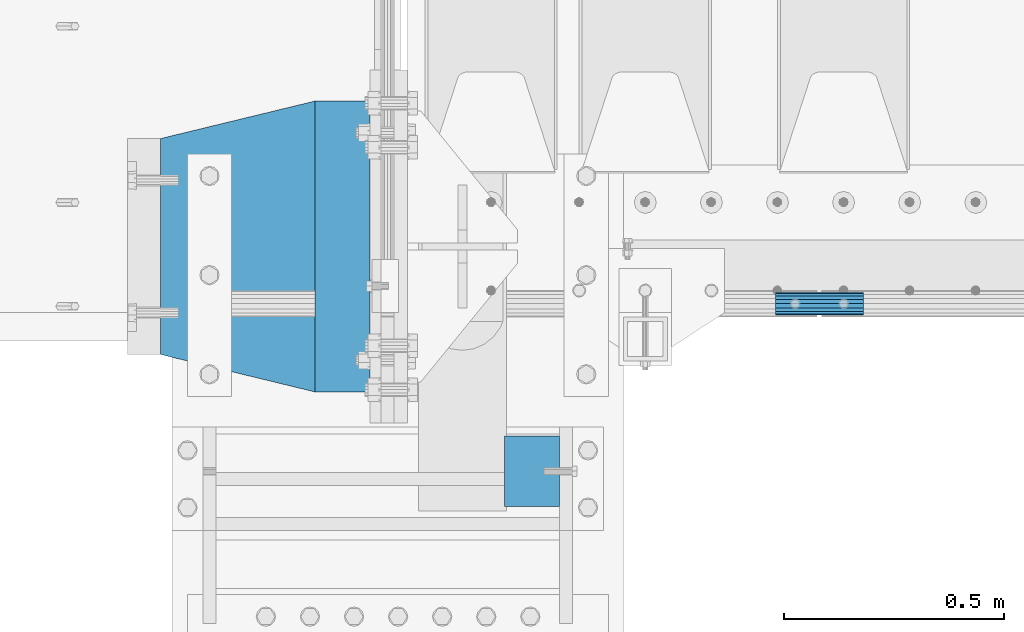
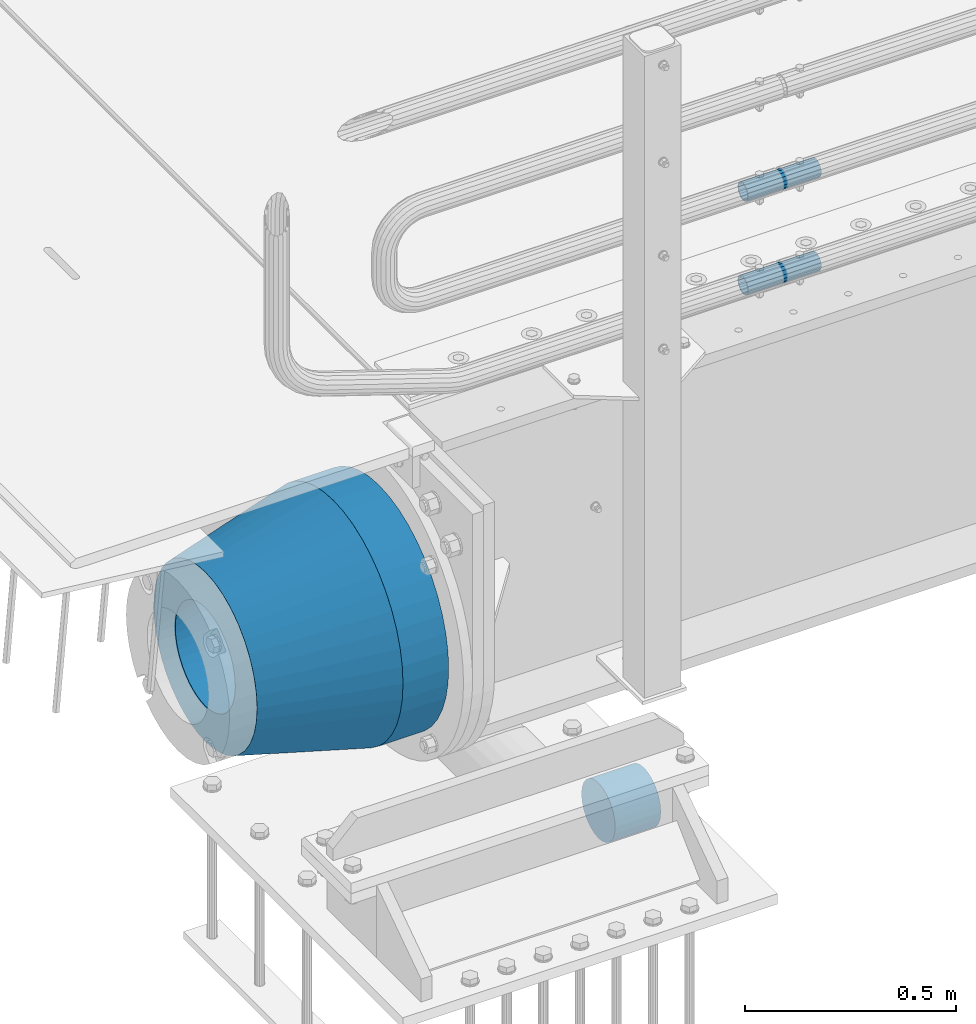
# One storey, part 137 of 247: 5 beams.
"""IFC2X3 building model written with IfcOpenShell, lengths in millimetres."""

from ifc_helpers import new_model, si_unit, frame, origin_with_axes, place, context, subcontext, project, spatial, faceted_brep, material, type_object, element, save


model = new_model("IFC2X3")

# Units and contexts
model_context = context("Model", 3, precision=1e-05, world=origin_with_axes())
body_context = subcontext(model_context, "Body", "Model", "MODEL_VIEW")
ifc_project = project(units=[si_unit("LENGTHUNIT", "METRE", prefix="MILLI"), si_unit("AREAUNIT", "SQUARE_METRE"), si_unit("VOLUMEUNIT", "CUBIC_METRE"), si_unit("MASSUNIT", "GRAM", prefix="KILO"), si_unit("TIMEUNIT", "SECOND"), si_unit("PLANEANGLEUNIT", "RADIAN"), si_unit("SOLIDANGLEUNIT", "STERADIAN"), si_unit("THERMODYNAMICTEMPERATUREUNIT", "DEGREE_CELSIUS"), si_unit("LUMINOUSINTENSITYUNIT", "LUMEN")], contexts=[model_context])

# Site, building, storey
site_placement = place(None, origin_with_axes())
site = spatial("IfcSite", under=ifc_project, at=site_placement, CompositionType="ELEMENT")
building_placement = place(site_placement, origin_with_axes())
building = spatial("IfcBuilding", under=site, at=building_placement, Name="Standard", CompositionType="ELEMENT")
storey_placement = place(building_placement, origin_with_axes())
storey = spatial("IfcBuildingStorey", under=building, at=storey_placement, Name="Undefined", CompositionType="ELEMENT", Elevation=0.0)

# Beams
ifc_material_1 = material()
beam_type_1 = type_object("IfcBeamType", PredefinedType="NOTDEFINED")
beam_1_placement = place(storey_placement, frame((230.000001139999, -510.000002261976, -923.000000000004), z_axis=(0.0, 0.0, -1.0), x_axis=(1.0, 0.0, 0.0)))
element("IfcBeam", 1, at=beam_1_placement, inside=storey, type_object=beam_type_1, material=ifc_material_1, context=body_context, shape_type="Brep", body=[
    faceted_brep([(2.8421709430404e-14, -80.0, 0.0), (2.8421709430404e-14, -77.2740661031254, -20.7055236082017), (125.0, -77.2740661031254, -20.7055236082017), (125.0, -80.0, 0.0), (2.8421709430404e-14, -69.2820323027551, -40.0), (125.0, -69.2820323027551, -40.0), (0.0, -56.5685424949238, -56.5685424949238), (125.0, -56.5685424949238, -56.5685424949238), (2.8421709430404e-14, -39.9999999999999, -69.2820323027552), (125.0, -39.9999999999999, -69.2820323027552), (2.8421709430404e-14, -20.7055236082016, -77.2740661031255), (125.0, -20.7055236082016, -77.2740661031255), (0.0, 0.0, -80.0), (125.0, 0.0, -80.0), (0.0, 20.7055236082018, -77.2740661031255), (125.0, 20.7055236082018, -77.2740661031255), (0.0, 40.0000000000001, -69.2820323027551), (125.0, 40.0000000000001, -69.2820323027551), (2.8421709430404e-14, 56.5685424949239, -56.5685424949238), (125.0, 56.5685424949239, -56.5685424949238), (0.0, 69.2820323027552, -40.0), (125.0, 69.2820323027551, -40.0), (0.0, 77.2740661031256, -20.7055236082016), (125.0, 77.2740661031256, -20.7055236082016), (0.0, 80.0000000000001, 0.0), (125.0, 80.0000000000001, 0.0), (0.0, 77.2740661031256, 20.7055236082017), (125.0, 77.2740661031254, 20.7055236082017), (0.0, 69.2820323027551, 40.0), (125.0, 69.2820323027551, 40.0), (2.8421709430404e-14, 56.5685424949239, 56.5685424949238), (125.0, 56.5685424949239, 56.5685424949238), (0.0, 40.0000000000001, 69.2820323027551), (125.0, 40.0000000000001, 69.2820323027551), (0.0, 20.7055236082018, 77.2740661031255), (125.0, 20.7055236082018, 77.2740661031255), (0.0, 0.0, 80.0), (125.0, 0.0, 80.0), (2.8421709430404e-14, -20.7055236082017, 77.2740661031255), (125.0, -20.7055236082017, 77.2740661031255), (2.8421709430404e-14, -40.0, 69.2820323027551), (125.0, -40.0, 69.2820323027551), (0.0, -56.5685424949238, 56.5685424949238), (125.0, -56.5685424949238, 56.5685424949238), (2.8421709430404e-14, -69.2820323027551, 40.0), (125.0, -69.2820323027551, 40.0), (2.8421709430404e-14, -77.2740661031254, 20.7055236082017), (125.0, -77.2740661031254, 20.7055236082017)], [[[0, 1, 2, 3]], [[1, 4, 5, 2]], [[4, 6, 7, 5]], [[6, 8, 9, 7]], [[8, 10, 11, 9]], [[10, 12, 13, 11]], [[12, 14, 15, 13]], [[14, 16, 17, 15]], [[16, 18, 19, 17]], [[18, 20, 21, 19]], [[20, 22, 23, 21]], [[22, 24, 25, 23]], [[24, 26, 27, 25]], [[26, 28, 29, 27]], [[28, 30, 31, 29]], [[30, 32, 33, 31]], [[32, 34, 35, 33]], [[34, 36, 37, 35]], [[36, 38, 39, 37]], [[38, 40, 41, 39]], [[40, 42, 43, 41]], [[42, 44, 45, 43]], [[44, 46, 47, 45]], [[46, 0, 3, 47]], [[5, 7, 9, 11, 13, 15, 17, 19, 21, 23, 25, 27, 29, 31, 33, 35, 37, 39, 41, 43, 45, 47, 3, 2]], [[46, 44, 42, 40, 38, 36, 34, 32, 30, 28, 26, 24, 22, 20, 18, 16, 14, 12, 10, 8, 6, 4, 1, 0]]]),
])
ifc_material_2 = material()
beam_type_2 = type_object("IfcBeamType", PredefinedType="NOTDEFINED")
beam_2_placement = place(storey_placement, frame((844.997502999948, -129.849999999603, 149.849999999725), z_axis=(0.0, 0.0, 1.0), x_axis=(1.0, 0.0, 0.0)))
element("IfcBeam", 2, at=beam_2_placement, inside=storey, type_object=beam_type_2, material=ifc_material_2, context=body_context, shape_type="Brep", body=[
    faceted_brep([(0.0, -21.8999999999996, 0.0), (0.0, -20.232961761998, 8.38076716879547), (200.0, -20.232961761998, 8.38076716879547), (200.0, -21.8999999999996, 0.0), (0.0, -15.4856385079856, 15.4856385079854), (200.0, -15.4856385079856, 15.4856385079854), (0.0, -8.3807671687955, 20.2329617619972), (200.0, -8.3807671687955, 20.2329617619972), (0.0, 0.0, 21.9), (200.0, 0.0, 21.9), (0.0, 8.3807671687955, 20.2329617619972), (200.0, 8.3807671687955, 20.2329617619972), (0.0, 15.4856385079856, 15.4856385079854), (200.0, 15.4856385079856, 15.4856385079854), (0.0, 20.232961761998, 8.38076716879547), (200.0, 20.232961761998, 8.38076716879547), (0.0, 21.8999999999996, 0.0), (200.0, 21.8999999999996, 0.0), (0.0, 20.232961761998, -8.38076716879547), (200.0, 20.232961761998, -8.38076716879547), (0.0, 15.4856385079856, -15.4856385079854), (200.0, 15.4856385079856, -15.4856385079854), (0.0, 8.3807671687955, -20.2329617619972), (200.0, 8.3807671687955, -20.2329617619972), (0.0, 0.0, -21.9), (200.0, 0.0, -21.9), (0.0, -8.3807671687955, -20.2329617619972), (200.0, -8.3807671687955, -20.2329617619972), (0.0, -15.4856385079856, -15.4856385079854), (200.0, -15.4856385079856, -15.4856385079854), (0.0, -20.232961761998, -8.38076716879547), (200.0, -20.232961761998, -8.38076716879547), (0.0, -25.5, 0.0), (0.0, -23.5589280790373, -9.7584275253098), (200.0, -23.5589280790373, -9.7584275253098), (200.0, -25.5, 0.0), (0.0, -18.0312229202573, -18.031222920257), (200.0, -18.0312229202573, -18.031222920257), (0.0, -9.75842752531025, -23.5589280790378), (200.0, -9.75842752531025, -23.5589280790378), (0.0, 0.0, -25.5), (200.0, 0.0, -25.5), (0.0, 9.75842752531025, -23.5589280790378), (200.0, 9.75842752531025, -23.5589280790378), (0.0, 18.0312229202573, -18.031222920257), (200.0, 18.0312229202573, -18.031222920257), (0.0, 23.5589280790373, -9.7584275253098), (200.0, 23.5589280790373, -9.7584275253098), (0.0, 25.5, 0.0), (200.0, 25.5, 0.0), (0.0, 23.5589280790373, 9.7584275253098), (200.0, 23.5589280790373, 9.7584275253098), (0.0, 18.0312229202573, 18.031222920257), (200.0, 18.0312229202573, 18.031222920257), (0.0, 9.75842752531025, 23.5589280790378), (200.0, 9.75842752531025, 23.5589280790378), (0.0, 0.0, 25.5), (200.0, 0.0, 25.5), (0.0, -9.75842752531025, 23.5589280790378), (200.0, -9.75842752531025, 23.5589280790378), (0.0, -18.0312229202573, 18.031222920257), (200.0, -18.0312229202573, 18.031222920257), (0.0, -23.5589280790373, 9.7584275253098), (200.0, -23.5589280790373, 9.7584275253098)], [[[0, 1, 2, 3]], [[1, 4, 5, 2]], [[4, 6, 7, 5]], [[6, 8, 9, 7]], [[8, 10, 11, 9]], [[10, 12, 13, 11]], [[12, 14, 15, 13]], [[14, 16, 17, 15]], [[16, 18, 19, 17]], [[18, 20, 21, 19]], [[20, 22, 23, 21]], [[22, 24, 25, 23]], [[24, 26, 27, 25]], [[26, 28, 29, 27]], [[28, 30, 31, 29]], [[30, 0, 3, 31]], [[32, 33, 34, 35]], [[33, 36, 37, 34]], [[36, 38, 39, 37]], [[38, 40, 41, 39]], [[40, 42, 43, 41]], [[42, 44, 45, 43]], [[44, 46, 47, 45]], [[46, 48, 49, 47]], [[48, 50, 51, 49]], [[50, 52, 53, 51]], [[52, 54, 55, 53]], [[54, 56, 57, 55]], [[56, 58, 59, 57]], [[58, 60, 61, 59]], [[60, 62, 63, 61]], [[62, 32, 35, 63]], [[37, 39, 41, 43, 45, 47, 49, 51, 53, 55, 57, 59, 61, 63, 35, 34], [5, 7, 9, 11, 13, 15, 17, 19, 21, 23, 25, 27, 29, 31, 3, 2]], [[62, 60, 58, 56, 54, 52, 50, 48, 46, 44, 42, 40, 38, 36, 33, 32], [30, 28, 26, 24, 22, 20, 18, 16, 14, 12, 10, 8, 6, 4, 1, 0]]]),
])
beam_3_placement = place(storey_placement, frame((844.997502999948, -129.849999999603, 420.149999999724), z_axis=(0.0, 0.0, 1.0), x_axis=(1.0, 0.0, 0.0)))
element("IfcBeam", 3, at=beam_3_placement, inside=storey, type_object=beam_type_2, material=ifc_material_2, context=body_context, shape_type="Brep", body=[
    faceted_brep([(0.0, -21.8999999999996, 0.0), (0.0, -20.232961761998, 8.38076716879547), (200.0, -20.232961761998, 8.38076716879547), (200.0, -21.8999999999996, 0.0), (0.0, -15.4856385079856, 15.4856385079854), (200.0, -15.4856385079856, 15.4856385079854), (0.0, -8.3807671687955, 20.2329617619972), (200.0, -8.3807671687955, 20.2329617619972), (0.0, 0.0, 21.9), (200.0, 0.0, 21.9), (0.0, 8.3807671687955, 20.2329617619972), (200.0, 8.3807671687955, 20.2329617619972), (0.0, 15.4856385079856, 15.4856385079854), (200.0, 15.4856385079856, 15.4856385079854), (0.0, 20.232961761998, 8.38076716879547), (200.0, 20.232961761998, 8.38076716879547), (0.0, 21.8999999999996, 0.0), (200.0, 21.8999999999996, 0.0), (0.0, 20.232961761998, -8.38076716879547), (200.0, 20.232961761998, -8.38076716879547), (0.0, 15.4856385079856, -15.4856385079854), (200.0, 15.4856385079856, -15.4856385079854), (0.0, 8.3807671687955, -20.2329617619972), (200.0, 8.3807671687955, -20.2329617619972), (0.0, 0.0, -21.9), (200.0, 0.0, -21.9), (0.0, -8.3807671687955, -20.2329617619972), (200.0, -8.3807671687955, -20.2329617619972), (0.0, -15.4856385079856, -15.4856385079854), (200.0, -15.4856385079856, -15.4856385079854), (0.0, -20.232961761998, -8.38076716879547), (200.0, -20.232961761998, -8.38076716879547), (0.0, -25.5, 0.0), (0.0, -23.5589280790373, -9.7584275253098), (200.0, -23.5589280790373, -9.7584275253098), (200.0, -25.5, 0.0), (0.0, -18.0312229202573, -18.031222920257), (200.0, -18.0312229202573, -18.031222920257), (0.0, -9.75842752531025, -23.5589280790378), (200.0, -9.75842752531025, -23.5589280790378), (0.0, 0.0, -25.5), (200.0, 0.0, -25.5), (0.0, 9.75842752531025, -23.5589280790378), (200.0, 9.75842752531025, -23.5589280790378), (0.0, 18.0312229202573, -18.031222920257), (200.0, 18.0312229202573, -18.031222920257), (0.0, 23.5589280790373, -9.7584275253098), (200.0, 23.5589280790373, -9.7584275253098), (0.0, 25.5, 0.0), (200.0, 25.5, 0.0), (0.0, 23.5589280790373, 9.7584275253098), (200.0, 23.5589280790373, 9.7584275253098), (0.0, 18.0312229202573, 18.031222920257), (200.0, 18.0312229202573, 18.031222920257), (0.0, 9.75842752531025, 23.5589280790378), (200.0, 9.75842752531025, 23.5589280790378), (0.0, 0.0, 25.5), (200.0, 0.0, 25.5), (0.0, -9.75842752531025, 23.5589280790378), (200.0, -9.75842752531025, 23.5589280790378), (0.0, -18.0312229202573, 18.031222920257), (200.0, -18.0312229202573, 18.031222920257), (0.0, -23.5589280790373, 9.7584275253098), (200.0, -23.5589280790373, 9.7584275253098)], [[[0, 1, 2, 3]], [[1, 4, 5, 2]], [[4, 6, 7, 5]], [[6, 8, 9, 7]], [[8, 10, 11, 9]], [[10, 12, 13, 11]], [[12, 14, 15, 13]], [[14, 16, 17, 15]], [[16, 18, 19, 17]], [[18, 20, 21, 19]], [[20, 22, 23, 21]], [[22, 24, 25, 23]], [[24, 26, 27, 25]], [[26, 28, 29, 27]], [[28, 30, 31, 29]], [[30, 0, 3, 31]], [[32, 33, 34, 35]], [[33, 36, 37, 34]], [[36, 38, 39, 37]], [[38, 40, 41, 39]], [[40, 42, 43, 41]], [[42, 44, 45, 43]], [[44, 46, 47, 45]], [[46, 48, 49, 47]], [[48, 50, 51, 49]], [[50, 52, 53, 51]], [[52, 54, 55, 53]], [[54, 56, 57, 55]], [[56, 58, 59, 57]], [[58, 60, 61, 59]], [[60, 62, 63, 61]], [[62, 32, 35, 63]], [[37, 39, 41, 43, 45, 47, 49, 51, 53, 55, 57, 59, 61, 63, 35, 34], [5, 7, 9, 11, 13, 15, 17, 19, 21, 23, 25, 27, 29, 31, 3, 2]], [[62, 60, 58, 56, 54, 52, 50, 48, 46, 44, 42, 40, 38, 36, 33, 32], [30, 28, 26, 24, 22, 20, 18, 16, 14, 12, 10, 8, 6, 4, 1, 0]]]),
])
ifc_material_3 = material(Name="STEEL/S355N")
beam_type_3 = type_object("IfcBeamType", PredefinedType="NOTDEFINED")
beam_4_placement = place(storey_placement, frame((-74.999999999991, 0.0, -515.0), z_axis=(0.0, 0.0, 1.0), x_axis=(-1.0, 0.0, 0.0)))
element("IfcBeam", 4, at=beam_4_placement, inside=storey, type_object=beam_type_3, material=ifc_material_3, context=body_context, shape_type="Brep", body=[
    faceted_brep([(0.0, -215.0, 0.0), (0.0, -212.811610004401, 30.5976902287563), (125.0, -212.811610004401, 30.5976902287563), (125.0, -215.0, 0.0), (0.0, -206.290989327117, 60.5724997209074), (125.0, -206.290989327117, 60.5724997209074), (0.0, -195.570879001221, 89.3142277954056), (125.0, -195.570879001221, 89.3142277954056), (0.0, -180.869509558705, 116.237775752953), (125.0, -180.869509558705, 116.237775752953), (0.0, -162.486158486165, 140.795057798236), (125.0, -162.486158486165, 140.795057798236), (0.0, -140.795057798236, 162.486158486165), (125.0, -140.795057798236, 162.486158486165), (0.0, -116.237775752954, 180.869509558704), (125.0, -116.237775752954, 180.869509558704), (0.0, -89.3142277954048, 195.570879001222), (125.0, -89.3142277954048, 195.570879001222), (0.0, -60.5724997209072, 206.290989327117), (125.0, -60.5724997209072, 206.290989327117), (0.0, -30.5976902287566, 212.811610004401), (125.0, -30.5976902287566, 212.811610004401), (0.0, 0.0, 215.0), (125.0, 0.0, 215.0), (0.0, 30.5976902287566, 212.811610004401), (125.0, 30.5976902287566, 212.811610004401), (0.0, 60.5724997209072, 206.290989327117), (125.0, 60.5724997209072, 206.290989327117), (0.0, 89.3142277954048, 195.570879001221), (125.0, 89.3142277954048, 195.570879001221), (0.0, 116.237775752954, 180.869509558704), (125.0, 116.237775752954, 180.869509558704), (0.0, 140.795057798236, 162.486158486165), (125.0, 140.795057798236, 162.486158486165), (0.0, 162.486158486165, 140.795057798236), (125.0, 162.486158486165, 140.795057798236), (0.0, 180.869509558705, 116.237775752953), (125.0, 180.869509558705, 116.237775752953), (0.0, 195.570879001221, 89.3142277954056), (125.0, 195.570879001221, 89.3142277954056), (0.0, 206.290989327117, 60.5724997209073), (125.0, 206.290989327117, 60.5724997209073), (0.0, 212.811610004401, 30.5976902287563), (125.0, 212.811610004401, 30.5976902287563), (0.0, 215.0, 0.0), (125.0, 215.0, 0.0), (0.0, 212.811610004401, -30.5976902287563), (125.0, 212.811610004401, -30.5976902287563), (0.0, 206.290989327117, -60.5724997209073), (125.0, 206.290989327117, -60.5724997209073), (0.0, 195.570879001221, -89.3142277954056), (125.0, 195.570879001221, -89.3142277954056), (0.0, 180.869509558705, -116.237775752954), (125.0, 180.869509558705, -116.237775752954), (0.0, 162.486158486165, -140.795057798236), (125.0, 162.486158486165, -140.795057798236), (0.0, 140.795057798236, -162.486158486166), (125.0, 140.795057798236, -162.486158486166), (0.0, 116.237775752954, -180.869509558704), (125.0, 116.237775752954, -180.869509558704), (0.0, 89.3142277954048, -195.570879001221), (125.0, 89.3142277954048, -195.570879001221), (0.0, 60.5724997209072, -206.290989327117), (125.0, 60.5724997209072, -206.290989327117), (0.0, 30.5976902287566, -212.811610004401), (125.0, 30.5976902287566, -212.811610004401), (0.0, 0.0, -215.0), (125.0, 0.0, -215.0), (0.0, -30.5976902287566, -212.811610004401), (125.0, -30.5976902287566, -212.811610004401), (0.0, -60.5724997209072, -206.290989327117), (125.0, -60.5724997209072, -206.290989327117), (0.0, -89.3142277954048, -195.570879001221), (125.0, -89.3142277954048, -195.570879001221), (0.0, -116.237775752954, -180.869509558704), (125.0, -116.237775752954, -180.869509558704), (0.0, -140.795057798236, -162.486158486166), (125.0, -140.795057798236, -162.486158486166), (0.0, -162.486158486165, -140.795057798236), (125.0, -162.486158486165, -140.795057798236), (0.0, -180.869509558705, -116.237775752953), (125.0, -180.869509558705, -116.237775752953), (0.0, -195.570879001221, -89.3142277954056), (125.0, -195.570879001221, -89.3142277954056), (0.0, -206.290989327117, -60.5724997209073), (125.0, -206.290989327117, -60.5724997209073), (0.0, -212.811610004401, -30.5976902287563), (125.0, -212.811610004401, -30.5976902287563), (0.0, -330.0, 0.0), (0.0, -326.641075820708, -46.9638966301842), (125.0, -326.641075820708, -46.9638966301842), (125.0, -330.0, 0.0), (0.0, -316.632681292784, -92.9717437576718), (125.0, -316.632681292784, -92.9717437576718), (0.0, -300.178558466991, -137.086954290623), (125.0, -300.178558466991, -137.086954290623), (0.0, -277.613665834289, -178.411469760347), (125.0, -277.613665834289, -178.411469760347), (0.0, -249.397359536906, -216.104042201944), (125.0, -249.397359536906, -216.104042201944), (0.0, -216.104042201943, -249.397359536905), (125.0, -216.104042201943, -249.397359536905), (0.0, -178.411469760347, -277.61366583429), (125.0, -178.411469760347, -277.61366583429), (0.0, -137.086954290622, -300.178558466991), (125.0, -137.086954290622, -300.178558466991), (0.0, -92.971743757671, -316.632681292784), (125.0, -92.971743757671, -316.632681292784), (0.0, -46.9638966301845, -326.641075820708), (125.0, -46.9638966301845, -326.641075820708), (0.0, 0.0, -330.0), (125.0, 0.0, -330.0), (0.0, 46.9638966301845, -326.641075820708), (125.0, 46.9638966301845, -326.641075820708), (0.0, 92.971743757671, -316.632681292784), (125.0, 92.971743757671, -316.632681292784), (0.0, 137.086954290622, -300.178558466991), (125.0, 137.086954290622, -300.178558466991), (0.0, 178.411469760347, -277.61366583429), (125.0, 178.411469760347, -277.61366583429), (0.0, 216.104042201943, -249.397359536905), (125.0, 216.104042201943, -249.397359536905), (0.0, 249.397359536906, -216.104042201944), (125.0, 249.397359536906, -216.104042201944), (0.0, 277.613665834289, -178.411469760347), (125.0, 277.613665834289, -178.411469760347), (0.0, 300.178558466991, -137.086954290623), (125.0, 300.178558466991, -137.086954290623), (0.0, 316.632681292784, -92.9717437576717), (125.0, 316.632681292784, -92.9717437576717), (0.0, 326.641075820708, -46.9638966301841), (125.0, 326.641075820708, -46.9638966301841), (0.0, 330.0, 0.0), (125.0, 330.0, 0.0), (0.0, 326.641075820708, 46.9638966301841), (125.0, 326.641075820708, 46.9638966301841), (0.0, 316.632681292784, 92.9717437576718), (125.0, 316.632681292784, 92.9717437576718), (0.0, 300.178558466991, 137.086954290622), (125.0, 300.178558466991, 137.086954290622), (0.0, 277.613665834289, 178.411469760347), (125.0, 277.613665834289, 178.411469760347), (0.0, 249.397359536904, 216.104042201944), (125.0, 249.397359536904, 216.104042201944), (0.0, 216.104042201943, 249.397359536905), (125.0, 216.104042201943, 249.397359536905), (0.0, 178.411469760347, 277.61366583429), (125.0, 178.411469760347, 277.61366583429), (0.0, 137.086954290622, 300.178558466991), (125.0, 137.086954290622, 300.178558466991), (0.0, 92.971743757671, 316.632681292784), (125.0, 92.971743757671, 316.632681292784), (0.0, 46.9638966301845, 326.641075820708), (125.0, 46.9638966301845, 326.641075820708), (0.0, 0.0, 330.0), (125.0, 0.0, 330.0), (0.0, -46.9638966301845, 326.641075820708), (125.0, -46.9638966301845, 326.641075820708), (0.0, -92.971743757671, 316.632681292784), (125.0, -92.971743757671, 316.632681292784), (0.0, -137.086954290622, 300.178558466991), (125.0, -137.086954290622, 300.178558466991), (0.0, -178.411469760347, 277.61366583429), (125.0, -178.411469760347, 277.61366583429), (0.0, -216.104042201943, 249.397359536905), (125.0, -216.104042201943, 249.397359536905), (0.0, -249.397359536906, 216.104042201944), (125.0, -249.397359536906, 216.104042201944), (0.0, -277.613665834289, 178.411469760347), (125.0, -277.613665834289, 178.411469760347), (0.0, -300.178558466991, 137.086954290623), (125.0, -300.178558466991, 137.086954290623), (0.0, -316.632681292784, 92.9717437576718), (125.0, -316.632681292784, 92.9717437576718), (0.0, -326.641075820708, 46.9638966301841), (125.0, -326.641075820708, 46.9638966301841)], [[[0, 1, 2, 3]], [[1, 4, 5, 2]], [[4, 6, 7, 5]], [[6, 8, 9, 7]], [[8, 10, 11, 9]], [[10, 12, 13, 11]], [[12, 14, 15, 13]], [[14, 16, 17, 15]], [[16, 18, 19, 17]], [[18, 20, 21, 19]], [[20, 22, 23, 21]], [[22, 24, 25, 23]], [[24, 26, 27, 25]], [[26, 28, 29, 27]], [[28, 30, 31, 29]], [[30, 32, 33, 31]], [[32, 34, 35, 33]], [[34, 36, 37, 35]], [[36, 38, 39, 37]], [[38, 40, 41, 39]], [[40, 42, 43, 41]], [[42, 44, 45, 43]], [[44, 46, 47, 45]], [[46, 48, 49, 47]], [[48, 50, 51, 49]], [[50, 52, 53, 51]], [[52, 54, 55, 53]], [[54, 56, 57, 55]], [[56, 58, 59, 57]], [[58, 60, 61, 59]], [[60, 62, 63, 61]], [[62, 64, 65, 63]], [[64, 66, 67, 65]], [[66, 68, 69, 67]], [[68, 70, 71, 69]], [[70, 72, 73, 71]], [[72, 74, 75, 73]], [[74, 76, 77, 75]], [[76, 78, 79, 77]], [[78, 80, 81, 79]], [[80, 82, 83, 81]], [[82, 84, 85, 83]], [[84, 86, 87, 85]], [[86, 0, 3, 87]], [[88, 89, 90, 91]], [[89, 92, 93, 90]], [[92, 94, 95, 93]], [[94, 96, 97, 95]], [[96, 98, 99, 97]], [[98, 100, 101, 99]], [[100, 102, 103, 101]], [[102, 104, 105, 103]], [[104, 106, 107, 105]], [[106, 108, 109, 107]], [[108, 110, 111, 109]], [[110, 112, 113, 111]], [[112, 114, 115, 113]], [[114, 116, 117, 115]], [[116, 118, 119, 117]], [[118, 120, 121, 119]], [[120, 122, 123, 121]], [[122, 124, 125, 123]], [[124, 126, 127, 125]], [[126, 128, 129, 127]], [[128, 130, 131, 129]], [[130, 132, 133, 131]], [[132, 134, 135, 133]], [[134, 136, 137, 135]], [[136, 138, 139, 137]], [[138, 140, 141, 139]], [[140, 142, 143, 141]], [[142, 144, 145, 143]], [[144, 146, 147, 145]], [[146, 148, 149, 147]], [[148, 150, 151, 149]], [[150, 152, 153, 151]], [[152, 154, 155, 153]], [[154, 156, 157, 155]], [[156, 158, 159, 157]], [[158, 160, 161, 159]], [[160, 162, 163, 161]], [[162, 164, 165, 163]], [[164, 166, 167, 165]], [[166, 168, 169, 167]], [[168, 170, 171, 169]], [[170, 172, 173, 171]], [[172, 174, 175, 173]], [[174, 88, 91, 175]], [[93, 95, 97, 99, 101, 103, 105, 107, 109, 111, 113, 115, 117, 119, 121, 123, 125, 127, 129, 131, 133, 135, 137, 139, 141, 143, 145, 147, 149, 151, 153, 155, 157, 159, 161, 163, 165, 167, 169, 171, 173, 175, 91, 90], [5, 7, 9, 11, 13, 15, 17, 19, 21, 23, 25, 27, 29, 31, 33, 35, 37, 39, 41, 43, 45, 47, 49, 51, 53, 55, 57, 59, 61, 63, 65, 67, 69, 71, 73, 75, 77, 79, 81, 83, 85, 87, 3, 2]], [[174, 172, 170, 168, 166, 164, 162, 160, 158, 156, 154, 152, 150, 148, 146, 144, 142, 140, 138, 136, 134, 132, 130, 128, 126, 124, 122, 120, 118, 116, 114, 112, 110, 108, 106, 104, 102, 100, 98, 96, 94, 92, 89, 88], [86, 84, 82, 80, 78, 76, 74, 72, 70, 68, 66, 64, 62, 60, 58, 56, 54, 52, 50, 48, 46, 44, 42, 40, 38, 36, 34, 32, 30, 28, 26, 24, 22, 20, 18, 16, 14, 12, 10, 8, 6, 4, 1, 0]]]),
])
ifc_material_4 = material(Name="SCN-500-E2")
beam_type_4 = type_object("IfcBeamType", PredefinedType="NOTDEFINED")
beam_5_placement = place(storey_placement, frame((-199.999999999991, 0.0, -515.0), z_axis=(0.0, 0.0, 1.0), x_axis=(-1.0, 0.0, 0.0)))
element("IfcBeam", 5, at=beam_5_placement, inside=storey, type_object=beam_type_4, material=ifc_material_4, context=body_context, shape_type="Brep", body=[
    faceted_brep([(0.0, -330.0, 0.0), (0.0, -326.641075820708, -46.9638966301842), (350.0, -242.506253260828, -34.8671353769549), (350.0, -245.0, 0.0), (0.0, -316.632681292784, -92.9717437576718), (350.0, -235.075778535553, -69.0244764261503), (0.0, -300.178558466991, -137.086954290623), (350.0, -222.859838861858, -101.776678185462), (0.0, -277.613665834289, -178.411469760347), (350.0, -206.10711554364, -132.457000276621), (0.0, -249.397359536906, -216.104042201944), (350.0, -185.158645716794, -160.440879816595), (0.0, -216.104042201943, -249.397359536905), (350.0, -160.440879816595, -185.158645716793), (0.0, -178.411469760347, -277.61366583429), (350.0, -132.457000276621, -206.107115543639), (0.0, -137.086954290622, -300.178558466991), (350.0, -101.776678185463, -222.859838861857), (0.0, -92.971743757671, -316.632681292784), (350.0, -69.0244764261497, -235.075778535552), (0.0, -46.9638966301845, -326.641075820708), (350.0, -34.867135376955, -242.506253260829), (0.0, 0.0, -330.0), (350.0, 0.0, -245.0), (0.0, 46.9638966301845, -326.641075820708), (350.0, 34.867135376955, -242.506253260829), (0.0, 92.971743757671, -316.632681292784), (350.0, 69.0244764261497, -235.075778535552), (0.0, 137.086954290622, -300.178558466991), (350.0, 101.776678185463, -222.859838861857), (0.0, 178.411469760347, -277.61366583429), (350.0, 132.457000276621, -206.107115543639), (0.0, 216.104042201943, -249.397359536905), (350.0, 160.440879816595, -185.158645716793), (0.0, 249.397359536906, -216.104042201944), (350.0, 185.158645716794, -160.440879816595), (0.0, 277.613665834289, -178.411469760347), (350.0, 206.10711554364, -132.457000276621), (0.0, 300.178558466991, -137.086954290623), (350.0, 222.859838861858, -101.776678185462), (0.0, 316.632681292784, -92.9717437576717), (350.0, 235.075778535553, -69.0244764261502), (0.0, 326.641075820708, -46.9638966301841), (350.0, 242.506253260828, -34.8671353769548), (0.0, 330.0, 0.0), (350.0, 245.0, 0.0), (0.0, 326.641075820708, 46.9638966301841), (350.0, 242.506253260828, 34.8671353769549), (0.0, 316.632681292784, 92.9717437576718), (350.0, 235.075778535553, 69.0244764261503), (0.0, 300.178558466991, 137.086954290622), (350.0, 222.859838861858, 101.776678185462), (0.0, 277.613665834289, 178.411469760347), (350.0, 206.10711554364, 132.457000276621), (0.0, 249.397359536904, 216.104042201944), (350.0, 185.158645716794, 160.440879816595), (0.0, 216.104042201943, 249.397359536905), (350.0, 160.440879816595, 185.158645716793), (0.0, 178.411469760347, 277.61366583429), (350.0, 132.457000276621, 206.107115543639), (0.0, 137.086954290622, 300.178558466991), (350.0, 101.776678185463, 222.859838861857), (0.0, 92.971743757671, 316.632681292784), (350.0, 69.0244764261497, 235.075778535552), (0.0, 46.9638966301845, 326.641075820708), (350.0, 34.867135376955, 242.506253260829), (0.0, 0.0, 330.0), (350.0, 0.0, 245.0), (0.0, -46.9638966301845, 326.641075820708), (350.0, -34.867135376955, 242.506253260829), (0.0, -92.971743757671, 316.632681292784), (350.0, -69.0244764261497, 235.075778535552), (0.0, -137.086954290622, 300.178558466991), (350.0, -101.776678185463, 222.859838861857), (0.0, -178.411469760347, 277.61366583429), (350.0, -132.457000276621, 206.107115543639), (0.0, -216.104042201943, 249.397359536905), (350.0, -160.440879816595, 185.158645716793), (0.0, -249.397359536906, 216.104042201944), (350.0, -185.158645716794, 160.440879816595), (0.0, -277.613665834289, 178.411469760347), (350.0, -206.10711554364, 132.457000276621), (0.0, -300.178558466991, 137.086954290623), (350.0, -222.859838861858, 101.776678185462), (0.0, -316.632681292784, 92.9717437576718), (350.0, -235.075778535553, 69.0244764261503), (0.0, -326.641075820708, 46.9638966301841), (350.0, -242.506253260828, 34.8671353769549), (0.0, -227.093265923131, 0.0), (0.0, -224.781783917484, 32.3187414128026), (350.0, -140.646961357605, 20.2219801595734), (350.0, -142.093265923131, 0.0), (0.0, -217.894393008413, 63.9795664499945), (350.0, -136.337490251181, 40.032299118473), (0.0, -206.571300613232, 94.3379520160985), (350.0, -129.252581008099, 59.0276759109381), (0.0, -191.043012240005, 122.775888927343), (350.0, -119.536461949354, 76.8214194436173), (0.0, -171.625639060125, 148.714462796454), (350.0, -107.386925240013, 93.0513004111044), (0.0, -148.714462796454, 171.625639060125), (350.0, -93.0513004111053, 107.386925240013), (0.0, -122.775888927343, 191.043012240005), (350.0, -76.8214194436168, 119.536461949355), (0.0, -94.3379520160979, 206.571300613232), (350.0, -59.0276759109383, 129.252581008098), (0.0, -63.9795664499943, 217.894393008413), (350.0, -40.032299118473, 136.337490251181), (0.0, -32.3187414128024, 224.781783917484), (350.0, -20.2219801595729, 140.646961357605), (0.0, 0.0, 227.093265923131), (350.0, 0.0, 142.093265923131), (0.0, 32.3187414128024, 224.781783917484), (350.0, 20.2219801595729, 140.646961357605), (0.0, 63.9795664499943, 217.894393008413), (350.0, 40.032299118473, 136.337490251181), (0.0, 94.3379520160979, 206.571300613232), (350.0, 59.0276759109383, 129.252581008098), (0.0, 122.775888927343, 191.043012240005), (350.0, 76.8214194436168, 119.536461949355), (0.0, 148.714462796454, 171.625639060125), (350.0, 93.0513004111053, 107.386925240013), (0.0, 171.625639060125, 148.714462796454), (350.0, 107.386925240013, 93.0513004111044), (0.0, 191.043012240005, 122.775888927343), (350.0, 119.536461949354, 76.8214194436174), (0.0, 206.571300613232, 94.3379520160985), (350.0, 129.252581008099, 59.0276759109382), (0.0, 217.894393008413, 63.9795664499945), (350.0, 136.337490251181, 40.032299118473), (0.0, 224.781783917484, 32.3187414128025), (350.0, 140.646961357605, 20.2219801595733), (0.0, 227.093265923131, 0.0), (350.0, 142.093265923131, 0.0), (0.0, 224.781783917484, -32.3187414128026), (350.0, 140.646961357605, -20.2219801595734), (0.0, 217.894393008413, -63.9795664499945), (350.0, 136.337490251181, -40.032299118473), (0.0, 206.571300613232, -94.3379520160985), (350.0, 129.252581008099, -59.0276759109381), (0.0, 191.043012240005, -122.775888927343), (350.0, 119.536461949354, -76.8214194436174), (0.0, 171.625639060125, -148.714462796454), (350.0, 107.386925240013, -93.0513004111044), (0.0, 148.714462796454, -171.625639060125), (350.0, 93.0513004111035, -107.386925240013), (0.0, 122.775888927343, -191.043012240005), (350.0, 76.8214194436168, -119.536461949355), (0.0, 94.3379520160979, -206.571300613232), (350.0, 59.0276759109383, -129.252581008098), (0.0, 63.9795664499943, -217.894393008413), (350.0, 40.032299118473, -136.337490251181), (0.0, 32.3187414128024, -224.781783917484), (350.0, 20.2219801595729, -140.646961357605), (0.0, 0.0, -227.093265923131), (350.0, 0.0, -142.093265923131), (0.0, -32.3187414128024, -224.781783917484), (350.0, -20.2219801595729, -140.646961357605), (0.0, -63.9795664499943, -217.894393008413), (350.0, -40.032299118473, -136.337490251181), (0.0, -94.3379520160979, -206.571300613232), (350.0, -59.0276759109383, -129.252581008098), (0.0, -122.775888927343, -191.043012240005), (350.0, -76.8214194436168, -119.536461949355), (0.0, -148.714462796454, -171.625639060125), (350.0, -93.0513004111035, -107.386925240013), (0.0, -171.625639060125, -148.714462796454), (350.0, -107.386925240013, -93.0513004111044), (0.0, -191.043012240005, -122.775888927343), (350.0, -119.536461949354, -76.8214194436174), (0.0, -206.571300613232, -94.3379520160985), (350.0, -129.252581008099, -59.0276759109381), (0.0, -217.894393008413, -63.9795664499945), (350.0, -136.337490251181, -40.032299118473), (0.0, -224.781783917484, -32.3187414128026), (350.0, -140.646961357605, -20.2219801595734)], [[[0, 1, 2, 3]], [[1, 4, 5, 2]], [[4, 6, 7, 5]], [[6, 8, 9, 7]], [[8, 10, 11, 9]], [[10, 12, 13, 11]], [[12, 14, 15, 13]], [[14, 16, 17, 15]], [[16, 18, 19, 17]], [[18, 20, 21, 19]], [[20, 22, 23, 21]], [[22, 24, 25, 23]], [[24, 26, 27, 25]], [[26, 28, 29, 27]], [[28, 30, 31, 29]], [[30, 32, 33, 31]], [[32, 34, 35, 33]], [[34, 36, 37, 35]], [[36, 38, 39, 37]], [[38, 40, 41, 39]], [[40, 42, 43, 41]], [[42, 44, 45, 43]], [[44, 46, 47, 45]], [[46, 48, 49, 47]], [[48, 50, 51, 49]], [[50, 52, 53, 51]], [[52, 54, 55, 53]], [[54, 56, 57, 55]], [[56, 58, 59, 57]], [[58, 60, 61, 59]], [[60, 62, 63, 61]], [[62, 64, 65, 63]], [[64, 66, 67, 65]], [[66, 68, 69, 67]], [[68, 70, 71, 69]], [[70, 72, 73, 71]], [[72, 74, 75, 73]], [[74, 76, 77, 75]], [[76, 78, 79, 77]], [[78, 80, 81, 79]], [[80, 82, 83, 81]], [[82, 84, 85, 83]], [[84, 86, 87, 85]], [[86, 0, 3, 87]], [[88, 89, 90, 91]], [[89, 92, 93, 90]], [[92, 94, 95, 93]], [[94, 96, 97, 95]], [[96, 98, 99, 97]], [[98, 100, 101, 99]], [[100, 102, 103, 101]], [[102, 104, 105, 103]], [[104, 106, 107, 105]], [[106, 108, 109, 107]], [[108, 110, 111, 109]], [[110, 112, 113, 111]], [[112, 114, 115, 113]], [[114, 116, 117, 115]], [[116, 118, 119, 117]], [[118, 120, 121, 119]], [[120, 122, 123, 121]], [[122, 124, 125, 123]], [[124, 126, 127, 125]], [[126, 128, 129, 127]], [[128, 130, 131, 129]], [[130, 132, 133, 131]], [[132, 134, 135, 133]], [[134, 136, 137, 135]], [[136, 138, 139, 137]], [[138, 140, 141, 139]], [[140, 142, 143, 141]], [[142, 144, 145, 143]], [[144, 146, 147, 145]], [[146, 148, 149, 147]], [[148, 150, 151, 149]], [[150, 152, 153, 151]], [[152, 154, 155, 153]], [[154, 156, 157, 155]], [[156, 158, 159, 157]], [[158, 160, 161, 159]], [[160, 162, 163, 161]], [[162, 164, 165, 163]], [[164, 166, 167, 165]], [[166, 168, 169, 167]], [[168, 170, 171, 169]], [[170, 172, 173, 171]], [[172, 174, 175, 173]], [[174, 88, 91, 175]], [[5, 7, 9, 11, 13, 15, 17, 19, 21, 23, 25, 27, 29, 31, 33, 35, 37, 39, 41, 43, 45, 47, 49, 51, 53, 55, 57, 59, 61, 63, 65, 67, 69, 71, 73, 75, 77, 79, 81, 83, 85, 87, 3, 2], [93, 95, 97, 99, 101, 103, 105, 107, 109, 111, 113, 115, 117, 119, 121, 123, 125, 127, 129, 131, 133, 135, 137, 139, 141, 143, 145, 147, 149, 151, 153, 155, 157, 159, 161, 163, 165, 167, 169, 171, 173, 175, 91, 90]], [[86, 84, 82, 80, 78, 76, 74, 72, 70, 68, 66, 64, 62, 60, 58, 56, 54, 52, 50, 48, 46, 44, 42, 40, 38, 36, 34, 32, 30, 28, 26, 24, 22, 20, 18, 16, 14, 12, 10, 8, 6, 4, 1, 0], [174, 172, 170, 168, 166, 164, 162, 160, 158, 156, 154, 152, 150, 148, 146, 144, 142, 140, 138, 136, 134, 132, 130, 128, 126, 124, 122, 120, 118, 116, 114, 112, 110, 108, 106, 104, 102, 100, 98, 96, 94, 92, 89, 88]]]),
])

save(model, "model.ifc")
